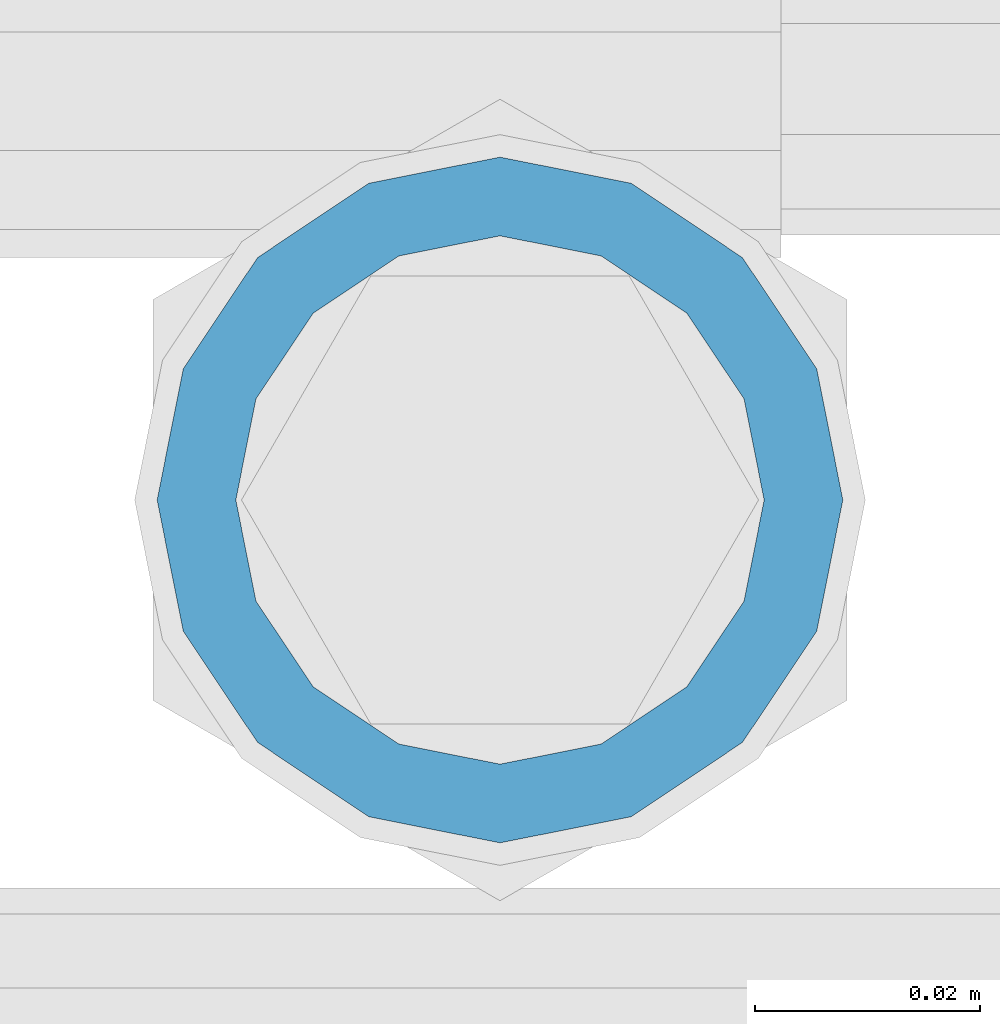
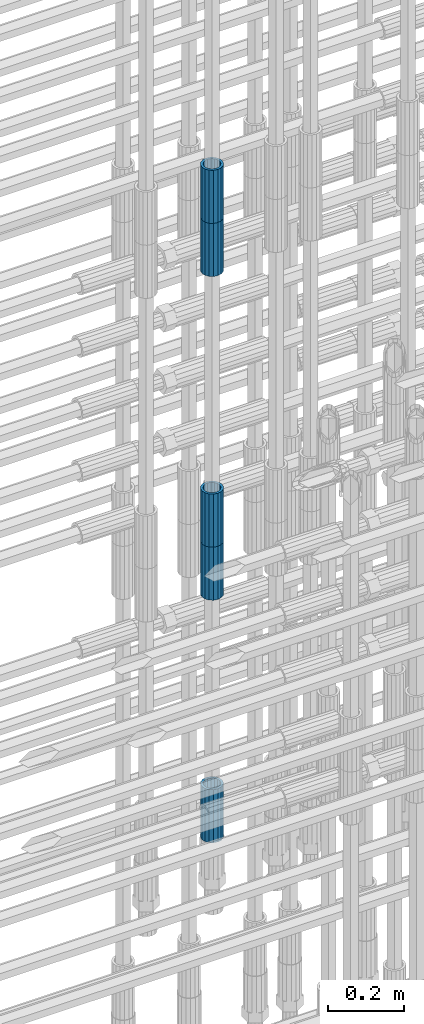
# One storey, part 31 of 119: 5 beams.
"""IFC2X3 building model written with IfcOpenShell, lengths in millimetres."""

import ifcopenshell
import ifcopenshell.guid

model = None  # the IFC model being written
_history = None  # IfcOwnerHistory: only IFC2X3 demands one
_inside = {}  # id of a spatial element -> (the spatial element, [elements in it])
_under = {}  # id of a project, library or spatial element -> (it, [spatial elements below it])
_declared = {}  # id of a project -> (the project, [libraries it declares])
_typed = {}  # id of a type object -> (the type object, [elements of that type])
_made_of = {}  # id of a material, layer set ... -> (it, [elements and type objects made of it])


def new_model(schema):
    """Start an empty IFC model of exactly this schema.

    Asked for "IFC4X3", IfcOpenShell would pick the latest addendum, in which some entities
    have other attributes; the version numbers below select the first issue.
    IFC2X3 requires an IfcOwnerHistory on every rooted entity: one is made here for all.
    """
    global model, _history
    if schema == "IFC4X3":
        model = ifcopenshell.file(schema_version=(4, 3, 0, 0))
    else:
        model = ifcopenshell.file(schema=schema)
    _inside.clear()
    _under.clear()
    _declared.clear()
    _typed.clear()
    _made_of.clear()
    _history = None
    if model.schema == "IFC2X3":
        org = make("IfcOrganization", Name="unknown")
        user = make(
            "IfcPersonAndOrganization",
            ThePerson=make("IfcPerson", FamilyName="unknown"),
            TheOrganization=org,
        )
        app = make(
            "IfcApplication",
            ApplicationDeveloper=org,
            Version="unknown",
            ApplicationFullName="unknown",
            ApplicationIdentifier="unknown",
        )
        _history = make(
            "IfcOwnerHistory",
            OwningUser=user,
            OwningApplication=app,
            ChangeAction="ADDED",
            CreationDate=0,
        )
    return model


def make(cls, **values):
    """One entity of the class cls with the attributes given. An attribute that is None is left unset."""
    return model.create_entity(
        cls, **{name: value for name, value in values.items() if value is not None}
    )


def rooted(cls, **values):
    """An entity with a GlobalId (a new one), such as an element, a storey or a relation."""
    return make(cls, GlobalId=ifcopenshell.guid.new(), OwnerHistory=_history, **values)


def si_unit(unit_type, name, prefix=None):
    """IfcSIUnit, for example si_unit("LENGTHUNIT", "METRE", prefix="MILLI")."""
    return make("IfcSIUnit", UnitType=unit_type, Prefix=prefix, Name=name)


def assignment(units):
    """IfcUnitAssignment: the units of a project."""
    return None if units is None else make("IfcUnitAssignment", Units=units)


def point(xyz):
    """IfcCartesianPoint."""
    return None if xyz is None else make("IfcCartesianPoint", Coordinates=xyz)


def direction(xyz):
    """IfcDirection."""
    return None if xyz is None else make("IfcDirection", DirectionRatios=xyz)


def frame(location, z_axis=None, x_axis=None):
    """IfcAxis2Placement3D, a coordinate frame: its origin and axes. An axis left out is left unset."""
    return make(
        "IfcAxis2Placement3D",
        Location=point(location),
        Axis=direction(z_axis),
        RefDirection=direction(x_axis),
    )


def origin_with_axes():
    """The frame at (0, 0, 0) with the z axis (0, 0, 1) and the x axis (1, 0, 0) written out."""
    return frame((0.0, 0.0, 0.0), z_axis=(0.0, 0.0, 1.0), x_axis=(1.0, 0.0, 0.0))


def place(relative_to, where):
    """IfcLocalPlacement: puts the frame where relative to a parent placement (None: the world)."""
    return make(
        "IfcLocalPlacement", PlacementRelTo=relative_to, RelativePlacement=where
    )


def context(
    kind, dimensions, precision=None, world=None, true_north=None, identifier=None
):
    """IfcGeometricRepresentationContext, for example the 3D "Model" context."""
    return make(
        "IfcGeometricRepresentationContext",
        ContextIdentifier=identifier,
        ContextType=kind,
        CoordinateSpaceDimension=dimensions,
        Precision=precision,
        WorldCoordinateSystem=world,
        TrueNorth=true_north,
    )


def subcontext(parent, identifier, kind, view, scale=None):
    """IfcGeometricRepresentationSubContext, for example "Body" below "Model"."""
    return make(
        "IfcGeometricRepresentationSubContext",
        ContextIdentifier=identifier,
        ContextType=kind,
        ParentContext=parent,
        TargetScale=scale,
        TargetView=view,
    )


def project(units=None, contexts=None):
    """IfcProject with its units and contexts."""
    return rooted(
        "IfcProject",
        Name="project",
        RepresentationContexts=contexts,
        UnitsInContext=assignment(units),
    )


def spatial(cls, under=None, at=None, **own):
    """A site, building, storey or space (cls), placed at a placement, below another one or the project."""
    s = rooted(cls, ObjectPlacement=at, **own)
    if under is not None:
        _under.setdefault(under.id(), (under, []))[1].append(s)
    return s


def faces_of(points, faces, orient=None, outer=None):
    """IfcFace entities. A face is a list of loops; a loop is a list of indices into points, from 0.

    orient and outer hold one flag for each loop. By default every Orientation is true, the
    first loop of a face is its IfcFaceOuterBound and the others are IfcFaceBound.
    """
    made = []
    for i, loops in enumerate(faces):
        bounds = []
        for j, loop in enumerate(loops):
            is_outer = j == 0 if outer is None else outer[i][j]
            bounds.append(
                make(
                    "IfcFaceOuterBound" if is_outer else "IfcFaceBound",
                    Bound=make("IfcPolyLoop", Polygon=[points[k] for k in loop]),
                    Orientation=True if orient is None else orient[i][j],
                )
            )
        made.append(make("IfcFace", Bounds=bounds))
    return made


def faceted_brep(points, faces, orient=None, outer=None, voids=None):
    """IfcFacetedBrep: a solid bounded by flat faces; with voids (closed shells), ...WithVoids."""
    shared = [point(p) for p in points]
    hull = make("IfcClosedShell", CfsFaces=faces_of(shared, faces, orient, outer))
    if voids is None:
        return make("IfcFacetedBrep", Outer=hull)
    return make(
        "IfcFacetedBrepWithVoids",
        Outer=hull,
        Voids=[
            make(cls, CfsFaces=faces_of(shared, fs, o, b)) for cls, fs, o, b in voids
        ],
    )


def shape(context_of_items, identifier, shape_type, items):
    """IfcShapeRepresentation: the items that make up one representation, for example the "Body"."""
    return make(
        "IfcShapeRepresentation",
        ContextOfItems=context_of_items,
        RepresentationIdentifier=identifier,
        RepresentationType=shape_type,
        Items=items,
    )


def material(Name=None, Category=None):
    """IfcMaterial."""
    return make("IfcMaterial", Name=Name, Category=Category)


def made_of(thing, what):
    """Note that an element or type object is made of a material, layer set ...; save() writes the relation."""
    if what is not None:
        _made_of.setdefault(what.id(), (what, []))[1].append(thing)
    return thing


def type_object(cls, material=None, **own):
    """A type object (cls), such as IfcWallType, which elements share."""
    return made_of(rooted(cls, **own), material)


def element(
    cls,
    number,
    at=None,
    inside=None,
    cuts=None,
    type_object=None,
    material=None,
    context=None,
    identifier="Body",
    shape_type=None,
    held_by="IfcProductDefinitionShape",
    body=None,
    shapes=None,
    **own,
):
    """One element of the class cls, such as IfcWall. Its Tag is "e" and its number.

    at: its placement. inside: the storey or other place that contains it. cuts: it is an
    opening in that element (IfcRelVoidsElement). A single representation is given by context,
    identifier, shape_type and body (its items); several are given by shapes. held_by: the class
    of the entity that holds the representations. save() writes the other relations.
    """
    e = rooted(cls, Tag="e%d" % number, ObjectPlacement=at, **own)
    if body is not None:
        shapes = [shape(context, identifier, shape_type, body)]
    if shapes is not None:
        e.Representation = make(held_by, Representations=shapes)
    if inside is not None:
        _inside.setdefault(inside.id(), (inside, []))[1].append(e)
    if cuts is not None:
        rooted(
            "IfcRelVoidsElement", RelatingBuildingElement=cuts, RelatedOpeningElement=e
        )
    if type_object is not None:
        _typed.setdefault(type_object.id(), (type_object, []))[1].append(e)
    return made_of(e, material)


def aggregate(whole, parts):
    """IfcRelAggregates: a whole, such as a stair, and the parts it consists of."""
    return rooted("IfcRelAggregates", RelatingObject=whole, RelatedObjects=parts)


def save(model, path):
    """Write the relations noted so far, then the file.

    IfcRelAggregates (storeys below a building ...), IfcRelContainedInSpatialStructure (elements
    in a storey), IfcRelDefinesByType, IfcRelAssociatesMaterial and IfcRelDeclares: one each for
    every whole, place, type object, material and project.
    """
    for whole, parts in _under.values():
        aggregate(whole, parts)
    for where, things in _inside.values():
        rooted(
            "IfcRelContainedInSpatialStructure",
            RelatedElements=things,
            RelatingStructure=where,
        )
    for kind, things in _typed.values():
        rooted("IfcRelDefinesByType", RelatedObjects=things, RelatingType=kind)
    for what, things in _made_of.values():
        rooted("IfcRelAssociatesMaterial", RelatedObjects=things, RelatingMaterial=what)
    for by, libraries in _declared.values():
        rooted("IfcRelDeclares", RelatingContext=by, RelatedDefinitions=libraries)
    model.write(path)


model = new_model("IFC2X3")

# Units and contexts
model_context = context("Model", 3, precision=1e-05, world=origin_with_axes())
body_context = subcontext(model_context, "Body", "Model", "MODEL_VIEW")
ifc_project = project(units=[si_unit("LENGTHUNIT", "METRE", prefix="MILLI"), si_unit("AREAUNIT", "SQUARE_METRE"), si_unit("VOLUMEUNIT", "CUBIC_METRE"), si_unit("MASSUNIT", "GRAM", prefix="KILO"), si_unit("TIMEUNIT", "SECOND"), si_unit("PLANEANGLEUNIT", "RADIAN"), si_unit("SOLIDANGLEUNIT", "STERADIAN"), si_unit("THERMODYNAMICTEMPERATUREUNIT", "DEGREE_CELSIUS"), si_unit("LUMINOUSINTENSITYUNIT", "LUMEN")], contexts=[model_context])

# Site, building, storey
site_placement = place(None, origin_with_axes())
site = spatial("IfcSite", under=ifc_project, at=site_placement, CompositionType="ELEMENT")
building_placement = place(site_placement, origin_with_axes())
building = spatial("IfcBuilding", under=site, at=building_placement, Name="Undefined", CompositionType="ELEMENT")
storey_placement = place(building_placement, origin_with_axes())
storey = spatial("IfcBuildingStorey", under=building, at=storey_placement, Name="Undefined", CompositionType="ELEMENT", Elevation=0.0)

# Beams
ifc_material = material(Name="STEEL/S275")
beam_type = type_object("IfcBeamType", PredefinedType="NOTDEFINED")
beam_1_placement = place(storey_placement, frame((2035324.99737119, 6206225.98580116, 21044.6068583141), z_axis=(-0.99999999999998, 1.98000110685822e-07, 0.0), x_axis=(0.0, 0.0, -1.0)))
element("IfcBeam", 1, at=beam_1_placement, inside=storey, type_object=beam_type, material=ifc_material, Name="AG40N", context=body_context, shape_type="Brep", body=[
    faceted_brep([(1.62981450557709e-09, -23.4999999990687, 0.0), (7.45058059692383e-09, -21.7111690142192, 8.99306066057534), (170.000002125278, -21.711168999318, 8.99306066022245), (170.000002127141, -23.4999999844003, -3.66071617463604e-10), (4.65661287307739e-09, -16.6170093587134, 16.6170093578889), (170.000002122484, -16.6170093440451, 16.6170093575288), (1.86264514923096e-09, -8.99306066217832, 21.7111690140277), (170.000002118759, -8.99306064750999, 21.7111690136603), (2.3283064365387e-10, 9.31322574615479e-10, 23.5), (170.000002114102, 1.28056854009628e-08, 23.4999999996485), (-6.51925802230835e-09, 8.99306065868586, 21.7111690140241), (170.00000211224, 8.99306067335419, 21.7111690136639), (-7.45058059692383e-09, 16.6170093561523, 16.6170093578853), (170.000002109446, 16.6170093708206, 16.6170093575324), (-9.31322574615479e-09, 21.711169013055, 8.99306066057534), (170.000002108514, 21.7111690277234, 8.99306066022245), (-1.16415321826935e-09, 23.5000000009313, 0.0), (170.000002108514, 23.5000000144355, -3.66071617463604e-10), (-8.38190317153931e-09, 21.7111690151505, -8.99306066059444), (170.000002110377, 21.7111690300517, -8.9930606609546), (-5.58793544769287e-09, 16.6170093598776, -16.6170093579008), (170.000002113171, 16.6170093745459, -16.6170093582609), (-9.31322574615479e-10, 8.99306066334248, -21.7111690140396), (170.000002115965, 8.99306067801081, -21.7111690143961), (2.3283064365387e-10, 9.31322574615479e-10, -23.5), (170.00000211969, 1.7927959561348e-08, -23.5000000003843), (5.58793544769287e-09, -8.99306065752171, -21.7111690140396), (170.000002123415, -8.99306064285338, -21.7111690143961), (8.38190317153931e-09, -16.6170093549881, -16.6170093579008), (170.000002125278, -16.6170093403198, -16.6170093582646), (9.31322574615479e-09, -21.7111690121237, -8.99306066059444), (170.000002127141, -21.7111689972226, -8.9930606609546), (1.11758708953857e-08, -30.4999999990687, -9.54969436861575e-12), (1.30385160446167e-08, -28.1783257392235, -11.6718446871514), (170.000002129003, -28.1783257243223, -11.6718446875116), (170.000002129935, -30.4999999841675, -3.66071617463604e-10), (1.02445483207703e-08, -21.5667568228673, -21.5667568262129), (170.000002128072, -21.566756808199, -21.5667568265694), (7.45058059692383e-09, -11.6718446831219, -28.1783257416196), (170.000002125278, -11.6718446684536, -28.1783257419834), (3.72529029846191e-09, 3.95812094211578e-09, -30.5000000000277), (170.00000211969, 1.83936208486557e-08, -30.5000000003879), (-9.31322574615479e-10, 11.6718446905725, -28.1783257416232), (170.000002115965, 11.6718447052408, -28.1783257419797), (-6.51925802230835e-09, 21.5667568286881, -21.5667568262093), (170.000002110377, 21.5667568433564, -21.5667568265694), (-9.31322574615479e-09, 28.178325742716, -11.6718446871478), (170.000002108514, 28.1783257573843, -11.6718446875079), (-1.21071934700012e-08, 30.5, -5.91171556152403e-12), (170.000002106652, 30.5000000144355, -3.62433638656512e-10), (-1.21071934700012e-08, 28.1783257401548, 11.6718446871359), (170.00000210572, 28.1783257548232, 11.6718446867794), (-1.02445483207703e-08, 21.5667568240315, 21.5667568261974), (170.000002107583, 21.566756838467, 21.5667568258409), (-7.45058059692383e-09, 11.671844684286, 28.1783257416041), (170.000002110377, 11.6718446989544, 28.178325741244), (-2.79396772384644e-09, -2.56113708019257e-09, 30.5000000000159), (170.000002114102, 1.18743628263474e-08, 30.4999999996558), (1.86264514923096e-09, -11.6718446896411, 28.1783257416114), (170.000002118759, -11.67184467474, 28.178325741244), (7.45058059692383e-09, -21.5667568275239, 21.5667568261974), (170.000002123415, -21.5667568126228, 21.5667568258373), (1.02445483207703e-08, -28.1783257415518, 11.6718446871359), (170.000002127141, -28.1783257271163, 11.6718446867794)], [[[0, 1, 2, 3]], [[1, 4, 5, 2]], [[4, 6, 7, 5]], [[6, 8, 9, 7]], [[8, 10, 11, 9]], [[10, 12, 13, 11]], [[12, 14, 15, 13]], [[14, 16, 17, 15]], [[16, 18, 19, 17]], [[18, 20, 21, 19]], [[20, 22, 23, 21]], [[22, 24, 25, 23]], [[24, 26, 27, 25]], [[26, 28, 29, 27]], [[28, 30, 31, 29]], [[30, 0, 3, 31]], [[32, 33, 34, 35]], [[33, 36, 37, 34]], [[36, 38, 39, 37]], [[38, 40, 41, 39]], [[40, 42, 43, 41]], [[42, 44, 45, 43]], [[44, 46, 47, 45]], [[46, 48, 49, 47]], [[48, 50, 51, 49]], [[50, 52, 53, 51]], [[52, 54, 55, 53]], [[54, 56, 57, 55]], [[56, 58, 59, 57]], [[58, 60, 61, 59]], [[60, 62, 63, 61]], [[62, 32, 35, 63]], [[37, 39, 41, 43, 45, 47, 49, 51, 53, 55, 57, 59, 61, 63, 35, 34], [5, 7, 9, 11, 13, 15, 17, 19, 21, 23, 25, 27, 29, 31, 3, 2]], [[62, 60, 58, 56, 54, 52, 50, 48, 46, 44, 42, 40, 38, 36, 33, 32], [30, 28, 26, 24, 22, 20, 18, 16, 14, 12, 10, 8, 6, 4, 1, 0]]]),
])
beam_2_placement = place(storey_placement, frame((2035324.99737119, 6206225.98580115, 20704.6057291635), z_axis=(1.0, 0.0, 0.0), x_axis=(0.0, 0.0, 1.0)))
element("IfcBeam", 2, at=beam_2_placement, inside=storey, type_object=beam_type, material=ifc_material, Name="AG40N", context=body_context, shape_type="Brep", body=[
    faceted_brep([(1.62981450557709e-09, -23.4999999990687, 0.0), (7.45058059692383e-09, -21.7111690142192, 8.99306066057534), (170.000002125278, -21.711168999318, 8.99306066022245), (170.000002127141, -23.4999999844003, -3.66071617463604e-10), (4.65661287307739e-09, -16.6170093587134, 16.6170093578889), (170.000002122484, -16.6170093440451, 16.6170093575288), (1.86264514923096e-09, -8.99306066217832, 21.7111690140277), (170.000002118759, -8.99306064750999, 21.7111690136603), (2.3283064365387e-10, 9.31322574615479e-10, 23.5), (170.000002114102, 1.28056854009628e-08, 23.4999999996485), (-6.51925802230835e-09, 8.99306065868586, 21.7111690140241), (170.00000211224, 8.99306067335419, 21.7111690136639), (-7.45058059692383e-09, 16.6170093561523, 16.6170093578853), (170.000002109446, 16.6170093708206, 16.6170093575324), (-9.31322574615479e-09, 21.711169013055, 8.99306066057534), (170.000002108514, 21.7111690277234, 8.99306066022245), (-1.16415321826935e-09, 23.5000000009313, 0.0), (170.000002108514, 23.5000000144355, -3.66071617463604e-10), (-8.38190317153931e-09, 21.7111690151505, -8.99306066059444), (170.000002110377, 21.7111690300517, -8.9930606609546), (-5.58793544769287e-09, 16.6170093598776, -16.6170093579008), (170.000002113171, 16.6170093745459, -16.6170093582609), (-9.31322574615479e-10, 8.99306066334248, -21.7111690140396), (170.000002115965, 8.99306067801081, -21.7111690143961), (2.3283064365387e-10, 9.31322574615479e-10, -23.5), (170.00000211969, 1.7927959561348e-08, -23.5000000003843), (5.58793544769287e-09, -8.99306065752171, -21.7111690140396), (170.000002123415, -8.99306064285338, -21.7111690143961), (8.38190317153931e-09, -16.6170093549881, -16.6170093579008), (170.000002125278, -16.6170093403198, -16.6170093582646), (9.31322574615479e-09, -21.7111690121237, -8.99306066059444), (170.000002127141, -21.7111689972226, -8.9930606609546), (1.11758708953857e-08, -30.4999999990687, -9.54969436861575e-12), (1.30385160446167e-08, -28.1783257392235, -11.6718446871514), (170.000002129003, -28.1783257243223, -11.6718446875116), (170.000002129935, -30.4999999841675, -3.66071617463604e-10), (1.02445483207703e-08, -21.5667568228673, -21.5667568262129), (170.000002128072, -21.566756808199, -21.5667568265694), (7.45058059692383e-09, -11.6718446831219, -28.1783257416196), (170.000002125278, -11.6718446684536, -28.1783257419834), (3.72529029846191e-09, 3.95812094211578e-09, -30.5000000000277), (170.00000211969, 1.83936208486557e-08, -30.5000000003879), (-9.31322574615479e-10, 11.6718446905725, -28.1783257416232), (170.000002115965, 11.6718447052408, -28.1783257419797), (-6.51925802230835e-09, 21.5667568286881, -21.5667568262093), (170.000002110377, 21.5667568433564, -21.5667568265694), (-9.31322574615479e-09, 28.178325742716, -11.6718446871478), (170.000002108514, 28.1783257573843, -11.6718446875079), (-1.21071934700012e-08, 30.5, -5.91171556152403e-12), (170.000002106652, 30.5000000144355, -3.62433638656512e-10), (-1.21071934700012e-08, 28.1783257401548, 11.6718446871359), (170.00000210572, 28.1783257548232, 11.6718446867794), (-1.02445483207703e-08, 21.5667568240315, 21.5667568261974), (170.000002107583, 21.566756838467, 21.5667568258409), (-7.45058059692383e-09, 11.671844684286, 28.1783257416041), (170.000002110377, 11.6718446989544, 28.178325741244), (-2.79396772384644e-09, -2.56113708019257e-09, 30.5000000000159), (170.000002114102, 1.18743628263474e-08, 30.4999999996558), (1.86264514923096e-09, -11.6718446896411, 28.1783257416114), (170.000002118759, -11.67184467474, 28.178325741244), (7.45058059692383e-09, -21.5667568275239, 21.5667568261974), (170.000002123415, -21.5667568126228, 21.5667568258373), (1.02445483207703e-08, -28.1783257415518, 11.6718446871359), (170.000002127141, -28.1783257271163, 11.6718446867794)], [[[0, 1, 2, 3]], [[1, 4, 5, 2]], [[4, 6, 7, 5]], [[6, 8, 9, 7]], [[8, 10, 11, 9]], [[10, 12, 13, 11]], [[12, 14, 15, 13]], [[14, 16, 17, 15]], [[16, 18, 19, 17]], [[18, 20, 21, 19]], [[20, 22, 23, 21]], [[22, 24, 25, 23]], [[24, 26, 27, 25]], [[26, 28, 29, 27]], [[28, 30, 31, 29]], [[30, 0, 3, 31]], [[32, 33, 34, 35]], [[33, 36, 37, 34]], [[36, 38, 39, 37]], [[38, 40, 41, 39]], [[40, 42, 43, 41]], [[42, 44, 45, 43]], [[44, 46, 47, 45]], [[46, 48, 49, 47]], [[48, 50, 51, 49]], [[50, 52, 53, 51]], [[52, 54, 55, 53]], [[54, 56, 57, 55]], [[56, 58, 59, 57]], [[58, 60, 61, 59]], [[60, 62, 63, 61]], [[62, 32, 35, 63]], [[37, 39, 41, 43, 45, 47, 49, 51, 53, 55, 57, 59, 61, 63, 35, 34], [5, 7, 9, 11, 13, 15, 17, 19, 21, 23, 25, 27, 29, 31, 3, 2]], [[62, 60, 58, 56, 54, 52, 50, 48, 46, 44, 42, 40, 38, 36, 33, 32], [30, 28, 26, 24, 22, 20, 18, 16, 14, 12, 10, 8, 6, 4, 1, 0]]]),
])
beam_3_placement = place(storey_placement, frame((2035324.99737119, 6206225.98580116, 20007.7168583139), z_axis=(-0.99999999999998, 1.98000110685822e-07, 0.0), x_axis=(0.0, 0.0, -1.0)))
element("IfcBeam", 3, at=beam_3_placement, inside=storey, type_object=beam_type, material=ifc_material, Name="AG40N", context=body_context, shape_type="Brep", body=[
    faceted_brep([(1.62981450557709e-09, -23.4999999990687, 0.0), (7.45058059692383e-09, -21.7111690142192, 8.99306066057534), (170.000002125278, -21.711168999318, 8.99306066022245), (170.000002127141, -23.4999999844003, -3.66071617463604e-10), (4.65661287307739e-09, -16.6170093587134, 16.6170093578889), (170.000002122484, -16.6170093440451, 16.6170093575288), (1.86264514923096e-09, -8.99306066217832, 21.7111690140277), (170.000002118759, -8.99306064750999, 21.7111690136603), (2.3283064365387e-10, 9.31322574615479e-10, 23.5), (170.000002114102, 1.28056854009628e-08, 23.4999999996485), (-6.51925802230835e-09, 8.99306065868586, 21.7111690140241), (170.00000211224, 8.99306067335419, 21.7111690136639), (-7.45058059692383e-09, 16.6170093561523, 16.6170093578853), (170.000002109446, 16.6170093708206, 16.6170093575324), (-9.31322574615479e-09, 21.711169013055, 8.99306066057534), (170.000002108514, 21.7111690277234, 8.99306066022245), (-1.16415321826935e-09, 23.5000000009313, 0.0), (170.000002108514, 23.5000000144355, -3.66071617463604e-10), (-8.38190317153931e-09, 21.7111690151505, -8.99306066059444), (170.000002110377, 21.7111690300517, -8.9930606609546), (-5.58793544769287e-09, 16.6170093598776, -16.6170093579008), (170.000002113171, 16.6170093745459, -16.6170093582609), (-9.31322574615479e-10, 8.99306066334248, -21.7111690140396), (170.000002115965, 8.99306067801081, -21.7111690143961), (2.3283064365387e-10, 9.31322574615479e-10, -23.5), (170.00000211969, 1.7927959561348e-08, -23.5000000003843), (5.58793544769287e-09, -8.99306065752171, -21.7111690140396), (170.000002123415, -8.99306064285338, -21.7111690143961), (8.38190317153931e-09, -16.6170093549881, -16.6170093579008), (170.000002125278, -16.6170093403198, -16.6170093582646), (9.31322574615479e-09, -21.7111690121237, -8.99306066059444), (170.000002127141, -21.7111689972226, -8.9930606609546), (1.11758708953857e-08, -30.4999999990687, -9.54969436861575e-12), (1.30385160446167e-08, -28.1783257392235, -11.6718446871514), (170.000002129003, -28.1783257243223, -11.6718446875116), (170.000002129935, -30.4999999841675, -3.66071617463604e-10), (1.02445483207703e-08, -21.5667568228673, -21.5667568262129), (170.000002128072, -21.566756808199, -21.5667568265694), (7.45058059692383e-09, -11.6718446831219, -28.1783257416196), (170.000002125278, -11.6718446684536, -28.1783257419834), (3.72529029846191e-09, 3.95812094211578e-09, -30.5000000000277), (170.00000211969, 1.83936208486557e-08, -30.5000000003879), (-9.31322574615479e-10, 11.6718446905725, -28.1783257416232), (170.000002115965, 11.6718447052408, -28.1783257419797), (-6.51925802230835e-09, 21.5667568286881, -21.5667568262093), (170.000002110377, 21.5667568433564, -21.5667568265694), (-9.31322574615479e-09, 28.178325742716, -11.6718446871478), (170.000002108514, 28.1783257573843, -11.6718446875079), (-1.21071934700012e-08, 30.5, -5.91171556152403e-12), (170.000002106652, 30.5000000144355, -3.62433638656512e-10), (-1.21071934700012e-08, 28.1783257401548, 11.6718446871359), (170.00000210572, 28.1783257548232, 11.6718446867794), (-1.02445483207703e-08, 21.5667568240315, 21.5667568261974), (170.000002107583, 21.566756838467, 21.5667568258409), (-7.45058059692383e-09, 11.671844684286, 28.1783257416041), (170.000002110377, 11.6718446989544, 28.178325741244), (-2.79396772384644e-09, -2.56113708019257e-09, 30.5000000000159), (170.000002114102, 1.18743628263474e-08, 30.4999999996558), (1.86264514923096e-09, -11.6718446896411, 28.1783257416114), (170.000002118759, -11.67184467474, 28.178325741244), (7.45058059692383e-09, -21.5667568275239, 21.5667568261974), (170.000002123415, -21.5667568126228, 21.5667568258373), (1.02445483207703e-08, -28.1783257415518, 11.6718446871359), (170.000002127141, -28.1783257271163, 11.6718446867794)], [[[0, 1, 2, 3]], [[1, 4, 5, 2]], [[4, 6, 7, 5]], [[6, 8, 9, 7]], [[8, 10, 11, 9]], [[10, 12, 13, 11]], [[12, 14, 15, 13]], [[14, 16, 17, 15]], [[16, 18, 19, 17]], [[18, 20, 21, 19]], [[20, 22, 23, 21]], [[22, 24, 25, 23]], [[24, 26, 27, 25]], [[26, 28, 29, 27]], [[28, 30, 31, 29]], [[30, 0, 3, 31]], [[32, 33, 34, 35]], [[33, 36, 37, 34]], [[36, 38, 39, 37]], [[38, 40, 41, 39]], [[40, 42, 43, 41]], [[42, 44, 45, 43]], [[44, 46, 47, 45]], [[46, 48, 49, 47]], [[48, 50, 51, 49]], [[50, 52, 53, 51]], [[52, 54, 55, 53]], [[54, 56, 57, 55]], [[56, 58, 59, 57]], [[58, 60, 61, 59]], [[60, 62, 63, 61]], [[62, 32, 35, 63]], [[37, 39, 41, 43, 45, 47, 49, 51, 53, 55, 57, 59, 61, 63, 35, 34], [5, 7, 9, 11, 13, 15, 17, 19, 21, 23, 25, 27, 29, 31, 3, 2]], [[62, 60, 58, 56, 54, 52, 50, 48, 46, 44, 42, 40, 38, 36, 33, 32], [30, 28, 26, 24, 22, 20, 18, 16, 14, 12, 10, 8, 6, 4, 1, 0]]]),
])
beam_4_placement = place(storey_placement, frame((2035324.99737119, 6206225.98580115, 19667.7157291635), z_axis=(1.0, 0.0, 0.0), x_axis=(0.0, 0.0, 1.0)))
element("IfcBeam", 4, at=beam_4_placement, inside=storey, type_object=beam_type, material=ifc_material, Name="AG40N", context=body_context, shape_type="Brep", body=[
    faceted_brep([(1.62981450557709e-09, -23.4999999990687, 0.0), (7.45058059692383e-09, -21.7111690142192, 8.99306066057534), (170.000002125278, -21.711168999318, 8.99306066022245), (170.000002127141, -23.4999999844003, -3.66071617463604e-10), (4.65661287307739e-09, -16.6170093587134, 16.6170093578889), (170.000002122484, -16.6170093440451, 16.6170093575288), (1.86264514923096e-09, -8.99306066217832, 21.7111690140277), (170.000002118759, -8.99306064750999, 21.7111690136603), (2.3283064365387e-10, 9.31322574615479e-10, 23.5), (170.000002114102, 1.28056854009628e-08, 23.4999999996485), (-6.51925802230835e-09, 8.99306065868586, 21.7111690140241), (170.00000211224, 8.99306067335419, 21.7111690136639), (-7.45058059692383e-09, 16.6170093561523, 16.6170093578853), (170.000002109446, 16.6170093708206, 16.6170093575324), (-9.31322574615479e-09, 21.711169013055, 8.99306066057534), (170.000002108514, 21.7111690277234, 8.99306066022245), (-1.16415321826935e-09, 23.5000000009313, 0.0), (170.000002108514, 23.5000000144355, -3.66071617463604e-10), (-8.38190317153931e-09, 21.7111690151505, -8.99306066059444), (170.000002110377, 21.7111690300517, -8.9930606609546), (-5.58793544769287e-09, 16.6170093598776, -16.6170093579008), (170.000002113171, 16.6170093745459, -16.6170093582609), (-9.31322574615479e-10, 8.99306066334248, -21.7111690140396), (170.000002115965, 8.99306067801081, -21.7111690143961), (2.3283064365387e-10, 9.31322574615479e-10, -23.5), (170.00000211969, 1.7927959561348e-08, -23.5000000003843), (5.58793544769287e-09, -8.99306065752171, -21.7111690140396), (170.000002123415, -8.99306064285338, -21.7111690143961), (8.38190317153931e-09, -16.6170093549881, -16.6170093579008), (170.000002125278, -16.6170093403198, -16.6170093582646), (9.31322574615479e-09, -21.7111690121237, -8.99306066059444), (170.000002127141, -21.7111689972226, -8.9930606609546), (1.11758708953857e-08, -30.4999999990687, -9.54969436861575e-12), (1.30385160446167e-08, -28.1783257392235, -11.6718446871514), (170.000002129003, -28.1783257243223, -11.6718446875116), (170.000002129935, -30.4999999841675, -3.66071617463604e-10), (1.02445483207703e-08, -21.5667568228673, -21.5667568262129), (170.000002128072, -21.566756808199, -21.5667568265694), (7.45058059692383e-09, -11.6718446831219, -28.1783257416196), (170.000002125278, -11.6718446684536, -28.1783257419834), (3.72529029846191e-09, 3.95812094211578e-09, -30.5000000000277), (170.00000211969, 1.83936208486557e-08, -30.5000000003879), (-9.31322574615479e-10, 11.6718446905725, -28.1783257416232), (170.000002115965, 11.6718447052408, -28.1783257419797), (-6.51925802230835e-09, 21.5667568286881, -21.5667568262093), (170.000002110377, 21.5667568433564, -21.5667568265694), (-9.31322574615479e-09, 28.178325742716, -11.6718446871478), (170.000002108514, 28.1783257573843, -11.6718446875079), (-1.21071934700012e-08, 30.5, -5.91171556152403e-12), (170.000002106652, 30.5000000144355, -3.62433638656512e-10), (-1.21071934700012e-08, 28.1783257401548, 11.6718446871359), (170.00000210572, 28.1783257548232, 11.6718446867794), (-1.02445483207703e-08, 21.5667568240315, 21.5667568261974), (170.000002107583, 21.566756838467, 21.5667568258409), (-7.45058059692383e-09, 11.671844684286, 28.1783257416041), (170.000002110377, 11.6718446989544, 28.178325741244), (-2.79396772384644e-09, -2.56113708019257e-09, 30.5000000000159), (170.000002114102, 1.18743628263474e-08, 30.4999999996558), (1.86264514923096e-09, -11.6718446896411, 28.1783257416114), (170.000002118759, -11.67184467474, 28.178325741244), (7.45058059692383e-09, -21.5667568275239, 21.5667568261974), (170.000002123415, -21.5667568126228, 21.5667568258373), (1.02445483207703e-08, -28.1783257415518, 11.6718446871359), (170.000002127141, -28.1783257271163, 11.6718446867794)], [[[0, 1, 2, 3]], [[1, 4, 5, 2]], [[4, 6, 7, 5]], [[6, 8, 9, 7]], [[8, 10, 11, 9]], [[10, 12, 13, 11]], [[12, 14, 15, 13]], [[14, 16, 17, 15]], [[16, 18, 19, 17]], [[18, 20, 21, 19]], [[20, 22, 23, 21]], [[22, 24, 25, 23]], [[24, 26, 27, 25]], [[26, 28, 29, 27]], [[28, 30, 31, 29]], [[30, 0, 3, 31]], [[32, 33, 34, 35]], [[33, 36, 37, 34]], [[36, 38, 39, 37]], [[38, 40, 41, 39]], [[40, 42, 43, 41]], [[42, 44, 45, 43]], [[44, 46, 47, 45]], [[46, 48, 49, 47]], [[48, 50, 51, 49]], [[50, 52, 53, 51]], [[52, 54, 55, 53]], [[54, 56, 57, 55]], [[56, 58, 59, 57]], [[58, 60, 61, 59]], [[60, 62, 63, 61]], [[62, 32, 35, 63]], [[37, 39, 41, 43, 45, 47, 49, 51, 53, 55, 57, 59, 61, 63, 35, 34], [5, 7, 9, 11, 13, 15, 17, 19, 21, 23, 25, 27, 29, 31, 3, 2]], [[62, 60, 58, 56, 54, 52, 50, 48, 46, 44, 42, 40, 38, 36, 33, 32], [30, 28, 26, 24, 22, 20, 18, 16, 14, 12, 10, 8, 6, 4, 1, 0]]]),
])
beam_5_placement = place(storey_placement, frame((2035324.99737119, 6206225.98580116, 19060.9668583144), z_axis=(-0.99999999999998, 1.98000110685822e-07, 0.0), x_axis=(0.0, 0.0, -1.0)))
element("IfcBeam", 5, at=beam_5_placement, inside=storey, type_object=beam_type, material=ifc_material, Name="AG40N", context=body_context, shape_type="Brep", body=[
    faceted_brep([(1.62981450557709e-09, -23.4999999990687, 0.0), (7.45058059692383e-09, -21.7111690142192, 8.99306066057534), (170.000002125278, -21.711168999318, 8.99306066022245), (170.000002127141, -23.4999999844003, -3.66071617463604e-10), (4.65661287307739e-09, -16.6170093587134, 16.6170093578889), (170.000002122484, -16.6170093440451, 16.6170093575288), (1.86264514923096e-09, -8.99306066217832, 21.7111690140277), (170.000002118759, -8.99306064750999, 21.7111690136603), (2.3283064365387e-10, 9.31322574615479e-10, 23.5), (170.000002114102, 1.28056854009628e-08, 23.4999999996485), (-6.51925802230835e-09, 8.99306065868586, 21.7111690140241), (170.00000211224, 8.99306067335419, 21.7111690136639), (-7.45058059692383e-09, 16.6170093561523, 16.6170093578853), (170.000002109446, 16.6170093708206, 16.6170093575324), (-9.31322574615479e-09, 21.711169013055, 8.99306066057534), (170.000002108514, 21.7111690277234, 8.99306066022245), (-1.16415321826935e-09, 23.5000000009313, 0.0), (170.000002108514, 23.5000000144355, -3.66071617463604e-10), (-8.38190317153931e-09, 21.7111690151505, -8.99306066059444), (170.000002110377, 21.7111690300517, -8.9930606609546), (-5.58793544769287e-09, 16.6170093598776, -16.6170093579008), (170.000002113171, 16.6170093745459, -16.6170093582609), (-9.31322574615479e-10, 8.99306066334248, -21.7111690140396), (170.000002115965, 8.99306067801081, -21.7111690143961), (2.3283064365387e-10, 9.31322574615479e-10, -23.5), (170.00000211969, 1.7927959561348e-08, -23.5000000003843), (5.58793544769287e-09, -8.99306065752171, -21.7111690140396), (170.000002123415, -8.99306064285338, -21.7111690143961), (8.38190317153931e-09, -16.6170093549881, -16.6170093579008), (170.000002125278, -16.6170093403198, -16.6170093582646), (9.31322574615479e-09, -21.7111690121237, -8.99306066059444), (170.000002127141, -21.7111689972226, -8.9930606609546), (1.11758708953857e-08, -30.4999999990687, -9.54969436861575e-12), (1.30385160446167e-08, -28.1783257392235, -11.6718446871514), (170.000002129003, -28.1783257243223, -11.6718446875116), (170.000002129935, -30.4999999841675, -3.66071617463604e-10), (1.02445483207703e-08, -21.5667568228673, -21.5667568262129), (170.000002128072, -21.566756808199, -21.5667568265694), (7.45058059692383e-09, -11.6718446831219, -28.1783257416196), (170.000002125278, -11.6718446684536, -28.1783257419834), (3.72529029846191e-09, 3.95812094211578e-09, -30.5000000000277), (170.00000211969, 1.83936208486557e-08, -30.5000000003879), (-9.31322574615479e-10, 11.6718446905725, -28.1783257416232), (170.000002115965, 11.6718447052408, -28.1783257419797), (-6.51925802230835e-09, 21.5667568286881, -21.5667568262093), (170.000002110377, 21.5667568433564, -21.5667568265694), (-9.31322574615479e-09, 28.178325742716, -11.6718446871478), (170.000002108514, 28.1783257573843, -11.6718446875079), (-1.21071934700012e-08, 30.5, -5.91171556152403e-12), (170.000002106652, 30.5000000144355, -3.62433638656512e-10), (-1.21071934700012e-08, 28.1783257401548, 11.6718446871359), (170.00000210572, 28.1783257548232, 11.6718446867794), (-1.02445483207703e-08, 21.5667568240315, 21.5667568261974), (170.000002107583, 21.566756838467, 21.5667568258409), (-7.45058059692383e-09, 11.671844684286, 28.1783257416041), (170.000002110377, 11.6718446989544, 28.178325741244), (-2.79396772384644e-09, -2.56113708019257e-09, 30.5000000000159), (170.000002114102, 1.18743628263474e-08, 30.4999999996558), (1.86264514923096e-09, -11.6718446896411, 28.1783257416114), (170.000002118759, -11.67184467474, 28.178325741244), (7.45058059692383e-09, -21.5667568275239, 21.5667568261974), (170.000002123415, -21.5667568126228, 21.5667568258373), (1.02445483207703e-08, -28.1783257415518, 11.6718446871359), (170.000002127141, -28.1783257271163, 11.6718446867794)], [[[0, 1, 2, 3]], [[1, 4, 5, 2]], [[4, 6, 7, 5]], [[6, 8, 9, 7]], [[8, 10, 11, 9]], [[10, 12, 13, 11]], [[12, 14, 15, 13]], [[14, 16, 17, 15]], [[16, 18, 19, 17]], [[18, 20, 21, 19]], [[20, 22, 23, 21]], [[22, 24, 25, 23]], [[24, 26, 27, 25]], [[26, 28, 29, 27]], [[28, 30, 31, 29]], [[30, 0, 3, 31]], [[32, 33, 34, 35]], [[33, 36, 37, 34]], [[36, 38, 39, 37]], [[38, 40, 41, 39]], [[40, 42, 43, 41]], [[42, 44, 45, 43]], [[44, 46, 47, 45]], [[46, 48, 49, 47]], [[48, 50, 51, 49]], [[50, 52, 53, 51]], [[52, 54, 55, 53]], [[54, 56, 57, 55]], [[56, 58, 59, 57]], [[58, 60, 61, 59]], [[60, 62, 63, 61]], [[62, 32, 35, 63]], [[37, 39, 41, 43, 45, 47, 49, 51, 53, 55, 57, 59, 61, 63, 35, 34], [5, 7, 9, 11, 13, 15, 17, 19, 21, 23, 25, 27, 29, 31, 3, 2]], [[62, 60, 58, 56, 54, 52, 50, 48, 46, 44, 42, 40, 38, 36, 33, 32], [30, 28, 26, 24, 22, 20, 18, 16, 14, 12, 10, 8, 6, 4, 1, 0]]]),
])

save(model, "model.ifc")
